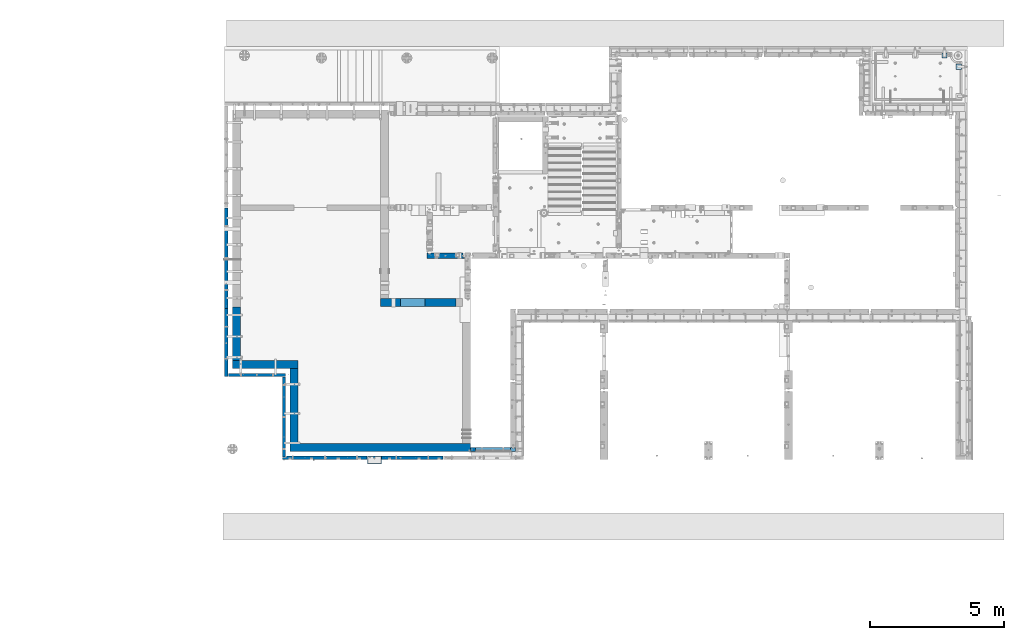
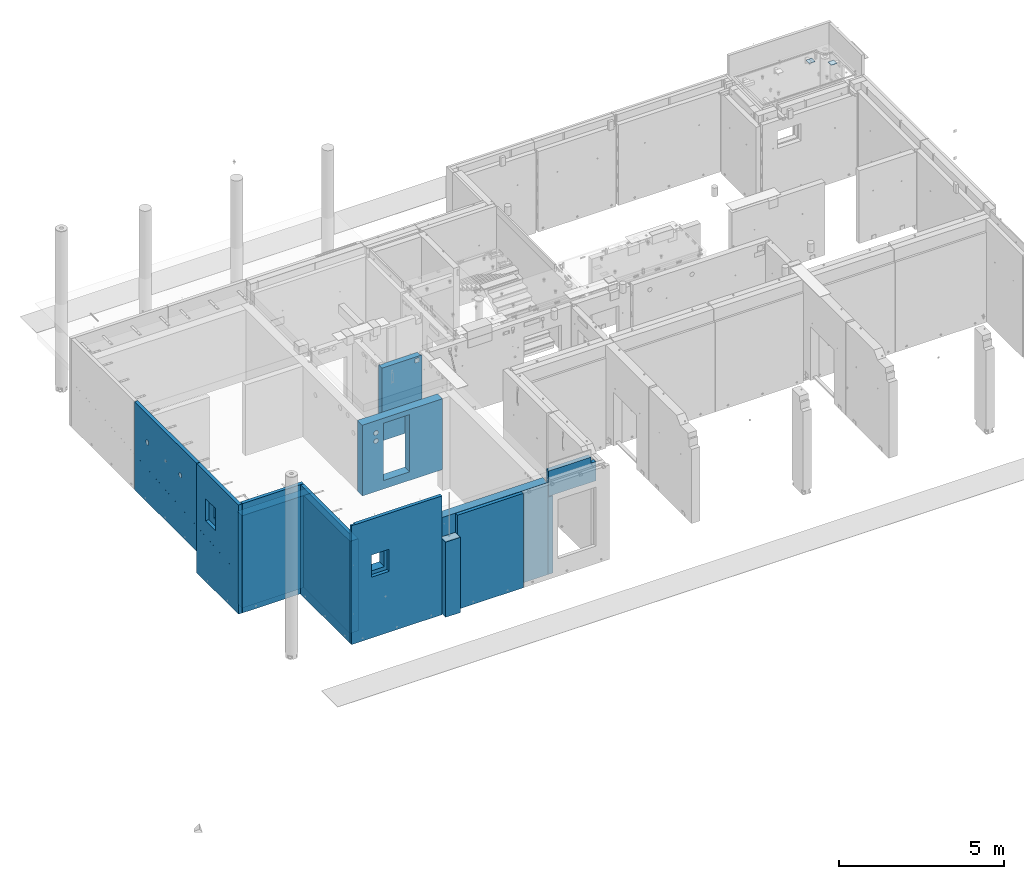
# One storey, part 170 of 264: 15 walls, 2 plates, 16 elements without a shape of their own.
"""IFC2X3 building model written with IfcOpenShell, lengths in millimetres."""

from ifc_helpers import new_model, si_unit, frame, origin_with_axes, place, context, subcontext, project, spatial, faceted_brep, material, type_object, element, aggregate, save


model = new_model("IFC2X3")

# Units and contexts
model_context = context("Model", 3, precision=1e-05, world=origin_with_axes())
body_context = subcontext(model_context, "Body", "Model", "MODEL_VIEW")
ifc_project = project(units=[si_unit("LENGTHUNIT", "METRE", prefix="MILLI"), si_unit("AREAUNIT", "SQUARE_METRE"), si_unit("VOLUMEUNIT", "CUBIC_METRE"), si_unit("MASSUNIT", "GRAM", prefix="KILO"), si_unit("TIMEUNIT", "SECOND"), si_unit("PLANEANGLEUNIT", "RADIAN"), si_unit("SOLIDANGLEUNIT", "STERADIAN"), si_unit("THERMODYNAMICTEMPERATUREUNIT", "DEGREE_CELSIUS"), si_unit("LUMINOUSINTENSITYUNIT", "LUMEN")], contexts=[model_context])

# Site, building, storey
site_placement = place(None, origin_with_axes())
site = spatial("IfcSite", under=ifc_project, at=site_placement, CompositionType="ELEMENT")
building_placement = place(site_placement, origin_with_axes())
building = spatial("IfcBuilding", under=site, at=building_placement, CompositionType="ELEMENT")
storey_placement = place(building_placement, origin_with_axes())
storey = spatial("IfcBuildingStorey", under=building, at=storey_placement, Name="K", CompositionType="ELEMENT", Elevation=0.0)

# Assemblies, plates
assembly_1_placement = place(storey_placement, origin_with_axes())
assembly_1 = element("IfcElementAssembly", 1, at=assembly_1_placement, inside=storey, AssemblyPlace="NOTDEFINED", PredefinedType="REINFORCEMENT_UNIT")
assembly_2_placement = place(assembly_1_placement, origin_with_axes())
assembly_2 = element("IfcElementAssembly", 2, at=assembly_2_placement, Name="Steel Assembly", AssemblyPlace="NOTDEFINED", PredefinedType="RIGID_FRAME")
ifc_material_1 = material(Name="STEEL/Steel_Undefined")
plate_type = type_object("IfcPlateType", PredefinedType="NOTDEFINED")
plate_1_placement = place(assembly_2_placement, frame((34934.9994523292, 22350.0101493348, 81451.0), z_axis=(-3.04539999856137e-05, -0.999999999536277, 0.0), x_axis=(0.999999999536277, -3.04539999891935e-05, 0.0)))
plate_1 = element("IfcPlate", 3, at=plate_1_placement, type_object=plate_type, material=ifc_material_1, Name="200x200", context=body_context, shape_type="Brep", body=[
    faceted_brep([(0.0, -6.0, -1.45519152283669e-11), (0.0, -6.0, 199.999999999996), (0.0, 6.0, 199.999999999996), (0.0, 6.0, -1.45519152283669e-11), (200.0, -6.0, 200.0), (200.0, 6.0, 200.0), (200.0, -6.0, -3.63797880709171e-12), (200.0, 6.0, -3.63797880709171e-12)], [[[0, 1, 2, 3]], [[1, 4, 5, 2]], [[4, 6, 7, 5]], [[6, 0, 3, 7]], [[5, 7, 3, 2]], [[6, 4, 1, 0]]]),
])
aggregate(assembly_2, [plate_1])
assembly_3_placement = place(assembly_1_placement, origin_with_axes())
assembly_3 = element("IfcElementAssembly", 4, at=assembly_3_placement, Name="Steel Assembly", AssemblyPlace="NOTDEFINED", PredefinedType="RIGID_FRAME")
aggregate(assembly_1, [assembly_2, assembly_3])
plate_2_placement = place(assembly_3_placement, frame((34399.9994523284, 22770.0101493342, 81451.0), z_axis=(-3.04539999856137e-05, -0.999999999536277, 0.0), x_axis=(0.999999999536277, -3.04539999891935e-05, 0.0)))
plate_2 = element("IfcPlate", 5, at=plate_2_placement, type_object=plate_type, material=ifc_material_1, Name="200x200", context=body_context, shape_type="Brep", body=[
    faceted_brep([(0.0, -6.0, -1.45519152283669e-11), (0.0, -6.0, 199.999999999996), (0.0, 6.0, 199.999999999996), (0.0, 6.0, -1.45519152283669e-11), (200.0, -6.0, 200.0), (200.0, 6.0, 200.0), (200.0, -6.0, -3.63797880709171e-12), (200.0, 6.0, -3.63797880709171e-12)], [[[0, 1, 2, 3]], [[1, 4, 5, 2]], [[4, 6, 7, 5]], [[6, 0, 3, 7]], [[5, 7, 3, 2]], [[6, 4, 1, 0]]]),
])
aggregate(assembly_3, [plate_2])

# Assembly, wall
assembly_4_placement = place(storey_placement, origin_with_axes())
assembly_4 = element("IfcElementAssembly", 6, at=assembly_4_placement, inside=storey, AssemblyPlace="NOTDEFINED", PredefinedType="REINFORCEMENT_UNIT")
ifc_material_2 = material(Name="CONCRETE/C40/50")
wall_type_1 = type_object("IfcWallType", PredefinedType="NOTDEFINED")
wall_1_placement = place(assembly_4_placement, frame((12910.0, 7530.00000961524, 79092.502949589), z_axis=(0.0, 0.0, 1.0), x_axis=(1.0, 0.0, 0.0)))
wall_1 = element("IfcWall", 7, at=wall_1_placement, type_object=wall_type_1, material=ifc_material_2, context=body_context, shape_type="Brep", body=[
    faceted_brep([(0.0, 150.0, -1392.5), (0.0, 150.0, 1392.5), (515.000007466682, 150.0, 1392.5), (515.000007466682, 150.0, -1392.5), (0.0, -150.0, 1392.5), (515.000007466682, -150.0, 1392.5), (0.0, -150.0, -1392.5), (515.000007466682, -150.0, -1392.5)], [[[0, 1, 2, 3]], [[1, 4, 5, 2]], [[4, 6, 7, 5]], [[6, 0, 3, 7]], [[5, 7, 3, 2]], [[6, 4, 1, 0]]]),
])

assembly_5_placement = place(storey_placement, origin_with_axes())
assembly_5 = element("IfcElementAssembly", 8, at=assembly_5_placement, inside=storey, AssemblyPlace="NOTDEFINED", PredefinedType="REINFORCEMENT_UNIT")
ifc_material_3 = material(Name="CONCRETE/Concrete_Undefined")
wall_type_2 = type_object("IfcWallType", PredefinedType="NOTDEFINED")
wall_2_placement = place(assembly_5_placement, frame((16850.0, 7850.00010372092, 79080.0), z_axis=(0.0, 0.0, 1.0), x_axis=(0.0, 1.0, 0.0)))
wall_2 = element("IfcWall", 9, at=wall_2_placement, type_object=wall_type_2, material=ifc_material_3, context=body_context, shape_type="Brep", body=[
    faceted_brep([(0.0, 90.0, -1430.0), (0.0, 90.0, 1430.0), (149.999961809157, 90.0, 1430.0), (149.999961809157, 90.0, -1430.0), (0.0, -90.0, 1430.0), (149.999961809157, -90.0, 1430.0), (0.0, -90.0, -1430.0), (149.999961809157, -90.0, -1430.0)], [[[0, 1, 2, 3]], [[1, 4, 5, 2]], [[4, 6, 7, 5]], [[6, 0, 3, 7]], [[5, 7, 3, 2]], [[6, 4, 1, 0]]]),
])

assembly_6_placement = place(storey_placement, origin_with_axes())
assembly_6 = element("IfcElementAssembly", 10, at=assembly_6_placement, inside=storey, AssemblyPlace="NOTDEFINED", PredefinedType="REINFORCEMENT_UNIT")
ifc_material_4 = material(Name="CONCRETE/C30/37")
wall_type_3 = type_object("IfcWallType", PredefinedType="NOTDEFINED")
wall_3_placement = place(assembly_6_placement, frame((18440.0000657818, 7925.00000000019, 81002.5), z_axis=(0.0, 0.0, 1.0), x_axis=(-1.0, 3.00000001838171e-08, 0.0)))
wall_3 = element("IfcWall", 11, at=wall_3_placement, type_object=wall_type_3, material=ifc_material_4, context=body_context, shape_type="Brep", body=[
    faceted_brep([(116.998555975799, -55.0010703084035, 237.5), (116.998555975799, -55.0010703084035, -467.500000000015), (129.998541787256, -75.0, -467.5), (129.998541787292, -75.0000042866541, 237.5), (42.9985568943812, -55.0010022399047, 237.5), (42.9985568943812, -55.0010022399047, -467.500000000015), (29.9985398258796, -75.0009920218718, 237.5), (29.9985398258832, -75.0, -467.5), (174.999743196975, -75.0000034214236, 467.5), (174.99987474698, 74.9999999999982, 467.5), (174.99987474698, 75.0, 237.5), (174.999743196975, -75.000005770552, 237.5), (1634.99903126282, -75.0000319658948, 467.5), (1634.99912738068, 32.0000269474131, 467.5), (1664.99906856749, 45.0000002495544, 467.5), (1664.99906856749, 74.9999999999991, 467.5), (1634.99903126282, -75.0, -467.5), (1634.99912738068, 32.0000269474131, -467.5), (1664.99906856749, 45.0000002495544, -467.5), (1664.99906856749, 74.9999999999991, -467.5), (0.0, 74.9999999999991, -467.5), (0.0, 74.9999999999991, 237.5), (-3.63797880709171e-12, -75.0, -467.5), (-3.63797880709171e-12, -75.0, 237.5)], [[[0, 1, 2, 3]], [[4, 5, 1, 0]], [[6, 7, 5, 4]], [[8, 9, 10, 11]], [[12, 13, 14, 15, 9, 8]], [[12, 16, 17, 13]], [[13, 17, 18, 14]], [[19, 15, 14, 18]], [[9, 15, 19, 20, 21, 10]], [[20, 22, 23, 21]], [[0, 3, 11, 10, 21, 23, 6, 4]], [[16, 12, 8, 11, 3, 2]], [[22, 20, 19, 18, 17, 16, 2, 1, 5, 7]], [[23, 22, 7, 6]]]),
])
aggregate(assembly_6, [wall_3])

# Wall
wall_type_4 = type_object("IfcWallType", PredefinedType="NOTDEFINED")
wall_4_placement = place(assembly_4_placement, frame((15735.0, 7620.0, 79445.0), z_axis=(0.0, 0.0, 1.0), x_axis=(-1.0, 3.00000001838171e-08, 0.0)))
wall_4 = element("IfcWall", 12, at=wall_4_placement, type_object=wall_type_4, material=ifc_material_2, context=body_context, shape_type="Brep", body=[
    faceted_brep([(0.0, 60.0, -1745.0), (0.0, 60.0, 1745.0), (2310.0, 60.0, 1745.0), (2310.0, 60.0, -1745.0), (0.0, -60.0, 1745.0), (2310.0, -60.0, 1745.0), (0.0, -60.0, -1745.0), (2310.0, -60.0, -1745.0)], [[[0, 1, 2, 3]], [[1, 4, 5, 2]], [[4, 6, 7, 5]], [[6, 0, 3, 7]], [[5, 7, 3, 2]], [[6, 4, 1, 0]]]),
])

aggregate(assembly_4, [wall_1, wall_4])

# Assembly, wall
assembly_7_placement = place(storey_placement, origin_with_axes())
assembly_7 = element("IfcElementAssembly", 13, at=assembly_7_placement, inside=storey, AssemblyPlace="NOTDEFINED", PredefinedType="REINFORCEMENT_UNIT")
wall_type_5 = type_object("IfcWallType", PredefinedType="NOTDEFINED")
wall_5_placement = place(assembly_7_placement, frame((12895.0, 7620.0, 79897.5), z_axis=(0.0, 0.0, 1.0), x_axis=(-1.0, 3.00000001838171e-08, 0.0)))
wall_5 = element("IfcWall", 14, at=wall_5_placement, type_object=wall_type_5, material=ifc_material_2, context=body_context, shape_type="Brep", body=[
    faceted_brep([(3025.0, -10.0, 2197.5), (3025.0, -10.0, 1292.5), (3175.0, -10.0, 1292.5), (3175.0, -10.0, 2197.5), (3025.0, -60.0, 2197.5), (3025.0, -60.0, 1292.5), (3175.0, -10.0, -2197.5), (3025.0, -10.0, -2197.5), (3025.0, -60.0, -2197.5), (0.0, -60.0, -2197.5), (0.0, 60.0, -2197.5), (3175.0, 60.0, -2197.5), (0.0, -60.0, 2197.5), (0.0, 60.0, 2197.5), (3175.0, 60.0, 2197.5), (2470.0695052743, 59.9996200203896, 52.5), (2470.0695052743, 59.9996200203896, 872.5), (1860.06912380457, 59.9996200203896, 872.5), (1860.06912380457, 59.9996200203896, 52.5), (1860.06912380457, -60.0, 52.5), (1860.06912380457, -60.0, 872.5), (2470.0695052743, -60.0, 52.5), (2470.0695052743, -60.0, 872.5)], [[[0, 1, 2, 3]], [[4, 5, 1, 0]], [[6, 2, 1, 7]], [[8, 7, 1, 5]], [[9, 10, 11, 6, 7, 8]], [[9, 12, 13, 10]], [[3, 14, 13, 12, 4, 0]], [[6, 11, 14, 3, 2]], [[10, 13, 14, 11], [15, 16, 17, 18]], [[19, 18, 17, 20]], [[21, 15, 18, 19]], [[22, 16, 15, 21]], [[20, 17, 16, 22]], [[12, 9, 8, 5, 4], [21, 19, 20, 22]]]),
])
aggregate(assembly_7, [wall_5])

# Wall
wall_type_6 = type_object("IfcWallType", PredefinedType="NOTDEFINED")
wall_6_placement = place(assembly_5_placement, frame((10010.0009314348, 7999.99701377227, 79355.0), z_axis=(0.0, 0.0, 1.0), x_axis=(1.0, 0.0, 0.0)))
wall_6 = element("IfcWall", 15, at=wall_6_placement, type_object=wall_type_6, material=ifc_material_3, context=body_context, shape_type="Brep", body=[
    faceted_brep([(6730.00003349592, -111.998474681339, 1705.0), (6730.00003349592, -111.998474681339, 1155.0), (6730.00003553767, -37.998474640417, 1155.0), (6730.00003553767, -37.998474640417, 1705.0), (6750.00003614728, -124.998473952346, 1705.0), (6750.00003427855, -124.998473952346, 1155.0), (6750.00003614728, -24.9984742298175, 1155.0), (6750.00003614728, -24.9984742298175, 1705.0), (0.0, -150.0, -1705.0), (0.0, -150.0, 1705.0), (0.0, 150.0, 1705.0), (0.0, 150.0, -1705.0), (6750.00003614728, 150.0, -1705.0), (6750.00003614728, -150.0, -1705.0), (6750.00003614728, -150.0, 1705.0), (414.929563290858, -150.0, 595.0), (414.929563290858, -150.0, 1415.0), (1024.92994476058, -150.0, 1415.0), (1024.92994476058, -150.0, 595.0), (1024.92994476058, 150.0, 595.0), (1024.92994476058, 150.0, 1415.0), (414.929563290858, 150.0, 595.0), (414.929563290858, 150.0, 1415.0), (6750.00003614728, 150.0, 1705.0)], [[[0, 1, 2, 3]], [[4, 5, 1, 0]], [[6, 2, 1, 5]], [[7, 3, 2, 6]], [[8, 9, 10, 11]], [[8, 11, 12, 13]], [[9, 8, 13, 14], [15, 16, 17, 18]], [[19, 18, 17, 20]], [[21, 15, 18, 19]], [[22, 16, 15, 21]], [[20, 17, 16, 22]], [[11, 10, 23, 12], [21, 19, 20, 22]], [[5, 4, 14, 13, 12, 23, 7, 6]], [[23, 10, 9, 14, 4, 0, 3, 7]]]),
])

aggregate(assembly_5, [wall_2, wall_6])

# Assembly, wall
assembly_8_placement = place(storey_placement, origin_with_axes())
assembly_8 = element("IfcElementAssembly", 16, at=assembly_8_placement, inside=storey, AssemblyPlace="NOTDEFINED", PredefinedType="REINFORCEMENT_UNIT")
wall_7_placement = place(assembly_8_placement, frame((10160.0039831927, 8150.00006553008, 79355.0), z_axis=(0.0, 0.0, 1.0), x_axis=(0.0, 1.0, 0.0)))
wall_7 = element("IfcWall", 17, at=wall_7_placement, type_object=wall_type_6, material=ifc_material_3, context=body_context, shape_type="Brep", body=[
    faceted_brep([(0.0, 150.0, -1705.0), (0.0, 150.0, 1705.0), (2800.00305175781, 150.0, 1705.0), (2800.00305175781, 150.0, -1705.0), (0.0, -150.0, 1705.0), (2800.00305175781, -150.0, 1705.0), (0.0, -150.0, -1705.0), (2800.00305175781, -150.0, -1705.0)], [[[0, 1, 2, 3]], [[1, 4, 5, 2]], [[4, 6, 7, 5]], [[6, 0, 3, 7]], [[5, 7, 3, 2]], [[6, 4, 1, 0]]]),
])
aggregate(assembly_8, [wall_7])

assembly_9_placement = place(storey_placement, origin_with_axes())
assembly_9 = element("IfcElementAssembly", 18, at=assembly_9_placement, inside=storey, AssemblyPlace="NOTDEFINED", PredefinedType="REINFORCEMENT_UNIT")
wall_8_placement = place(assembly_9_placement, frame((7850.00001965494, 11100.0031172879, 79355.0), z_axis=(0.0, 0.0, 1.0), x_axis=(1.0, 0.0, 0.0)))
wall_8 = element("IfcWall", 19, at=wall_8_placement, type_object=wall_type_6, material=ifc_material_3, context=body_context, shape_type="Brep", body=[
    faceted_brep([(0.0, 150.0, -1705.0), (0.0, 150.0, 1705.0), (2460.00396353772, 150.0, 1705.0), (2460.00396353772, 150.0, -1705.0), (0.0, -150.0, 1705.0), (2460.00396353772, -150.0, 1705.0), (0.0, -150.0, -1705.0), (2460.00396353772, -150.0, -1705.0)], [[[0, 1, 2, 3]], [[1, 4, 5, 2]], [[4, 6, 7, 5]], [[6, 0, 3, 7]], [[5, 7, 3, 2]], [[6, 4, 1, 0]]]),
])
aggregate(assembly_9, [wall_8])

assembly_10_placement = place(storey_placement, origin_with_axes())
assembly_10 = element("IfcElementAssembly", 20, at=assembly_10_placement, inside=storey, AssemblyPlace="NOTDEFINED", PredefinedType="REINFORCEMENT_UNIT")
wall_9_placement = place(assembly_10_placement, frame((8000.00032108328, 11249.9985396512, 79355.0), z_axis=(0.0, 0.0, 1.0), x_axis=(0.0, 1.0, 0.0)))
wall_9 = element("IfcWall", 21, at=wall_9_placement, type_object=wall_type_6, material=ifc_material_3, context=body_context, shape_type="Brep", body=[
    faceted_brep([(1410.00195476936, -150.0, 595.0), (1410.00195476936, 150.0, 595.0), (800.001573299629, 150.0, 595.0), (800.001573299629, -150.0, 595.0), (800.001573299629, 150.0, 1415.0), (800.001573299629, -150.0, 1415.0), (1410.00195476936, 150.0, 1415.0), (1410.00195476936, -150.0, 1415.0), (0.0, -150.0, 1705.0), (0.0, -150.0, -1705.0), (2005.00146034883, -150.0, -1705.0), (2005.00146034883, -150.0, 1705.0), (0.0, 150.0, 1705.0), (2005.00146034883, 150.0, 1705.0), (0.0, 150.0, -1705.0), (2005.00146034883, 150.0, -1705.0)], [[[0, 1, 2, 3]], [[3, 2, 4, 5]], [[5, 4, 6, 7]], [[7, 6, 1, 0]], [[8, 9, 10, 11], [3, 5, 7, 0]], [[12, 8, 11, 13]], [[9, 8, 12, 14]], [[9, 14, 15, 10]], [[11, 10, 15, 13]], [[14, 12, 13, 15], [2, 1, 6, 4]]]),
])
aggregate(assembly_10, [wall_9])

assembly_11_placement = place(storey_placement, origin_with_axes())
assembly_11 = element("IfcElementAssembly", 22, at=assembly_11_placement, inside=storey, AssemblyPlace="NOTDEFINED", PredefinedType="REINFORCEMENT_UNIT")
ifc_material_5 = material(Name="CONCRETE/C25/30")
wall_type_7 = type_object("IfcWallType", PredefinedType="NOTDEFINED")
wall_10_placement = place(assembly_11_placement, frame((15130.0, 15180.0, 80122.5), z_axis=(0.0, 0.0, 1.0), x_axis=(1.0, 0.0, 0.0)))
wall_10 = element("IfcWall", 23, at=wall_10_placement, type_object=wall_type_7, material=ifc_material_5, context=body_context, shape_type="Brep", body=[
    faceted_brep([(1149.99992221594, 100.0, 1287.50244328768), (1149.99992221594, -100.0, 1287.50244328768), (1149.99992221594, -100.0, 1137.50244328768), (1149.99992221594, 100.0, 1137.50244328768), (1299.99992221594, -100.0, 1137.50244328768), (1299.99992221594, 100.0, 1137.50244328768), (1299.99992221594, -100.0, 1287.50244328768), (1299.99992221594, 100.0, 1287.50244328768), (165.0, 100.0, 1347.5), (165.0, 100.0, -1347.5), (152.0, 80.0, -1347.5), (152.0, 80.0, 1347.5), (48.0, 80.0, -1347.5), (48.0, 80.0, 1347.5), (34.9999999999982, 100.0, -1347.5), (34.9999999999982, 100.0, 1347.5), (0.0, 100.0, -1347.5), (0.0, 100.0, 1347.5), (0.0, -100.0, -1347.5), (0.0, -100.0, 1347.5), (1350.0, 100.0, 1347.5), (1400.0, -100.0, 1347.5), (1400.0, -69.9999999999982, 1347.5), (1350.0, -57.0, 1347.5), (1350.0, 100.0, -1347.5), (1400.0, -100.0, -1347.5), (1350.0, -57.0, -1347.5), (1400.0, -69.9999999999982, -1347.5)], [[[0, 1, 2, 3]], [[3, 2, 4, 5]], [[5, 4, 6, 7]], [[7, 6, 1, 0]], [[8, 9, 10, 11]], [[11, 10, 12, 13]], [[13, 12, 14, 15]], [[16, 17, 15, 14]], [[18, 19, 17, 16]], [[20, 8, 11, 13, 15, 17, 19, 21, 22, 23]], [[9, 8, 20, 24], [3, 5, 7, 0]], [[25, 18, 16, 14, 12, 10, 9, 24, 26, 27]], [[20, 23, 26, 24]], [[22, 27, 26, 23]], [[21, 25, 27, 22]], [[19, 18, 25, 21], [2, 1, 6, 4]]]),
])
aggregate(assembly_11, [wall_10])

assembly_12_placement = place(storey_placement, origin_with_axes())
assembly_12 = element("IfcElementAssembly", 24, at=assembly_12_placement, inside=storey, AssemblyPlace="NOTDEFINED", PredefinedType="REINFORCEMENT_UNIT")
wall_type_8 = type_object("IfcWallType", PredefinedType="NOTDEFINED")
wall_11_placement = place(assembly_12_placement, frame((7620.0, 13210.0, 80115.0), z_axis=(0.0, 0.0, 1.0), x_axis=(0.0, 1.0, 0.0)))
wall_11 = element("IfcWall", 25, at=wall_11_placement, type_object=wall_type_8, material=ifc_material_2, context=body_context, shape_type="Brep", body=[
    faceted_brep([(3760.0, 60.0, -309.574801838578), (0.0, 60.0, -685.574801838578), (0.0, 59.0002685189247, -685.574801838578), (3760.0, 59.0002685189247, -309.574801838578), (3760.0, 59.0002685189247, -294.499988406882), (0.0, 59.0002685189247, -670.499988406882), (0.0, 60.0, -670.499988406897), (3760.0, 60.0, -294.499988406897), (1.81898940354586e-12, 60.0000000000036, 1625.0), (3.63797880709171e-12, -59.9999999999927, 1625.0), (3760.0, -60.0, 1625.0), (3760.0, 60.0, 1625.0), (3.63797880709171e-12, -59.9999999999927, -1625.0), (1.81898940354586e-12, 60.0000000000036, -1625.0), (3760.0, 60.0, -1625.0), (3760.0, -60.0, -1625.0), (3047.27322537961, -60.0, 615.705523608209), (3047.27322537961, 60.0, 615.705523608209), (3049.99915927648, 60.0, 595.0), (3049.99915927648, -60.0, 595.0), (3039.28119157924, -60.0, 635.0), (3039.28119157924, 60.0, 635.0), (3026.56770177141, -60.0, 651.568542494919), (3026.56770177141, 60.0, 651.568542494919), (3009.99915927648, -60.0, 664.282032302755), (3009.99915927648, 60.0, 664.282032302755), (2990.70468288469, -60.0, 672.274066103128), (2990.70468288469, 60.0, 672.274066103128), (2969.99915927648, -60.0, 675.0), (2969.99915927648, 60.0, 675.0), (2949.29363566828, -60.0, 672.274066103128), (2949.29363566828, 60.0, 672.274066103128), (2929.99915927648, -60.0, 664.282032302755), (2929.99915927648, 60.0, 664.282032302755), (2913.43061678156, -60.0, 651.568542494919), (2913.43061678156, 60.0, 651.568542494919), (2900.71712697373, -60.0, 635.0), (2900.71712697373, 60.0, 635.0), (2892.72509317336, -60.0, 615.705523608209), (2892.72509317336, 60.0, 615.705523608209), (2889.99915927648, -60.0, 595.0), (2889.99915927648, 60.0, 595.0), (2892.72509317336, -60.0, 574.294476391791), (2892.72509317336, 60.0, 574.294476391791), (2900.71712697373, -60.0, 555.0), (2900.71712697373, 60.0, 555.0), (2913.43061678156, -60.0, 538.431457505081), (2913.43061678156, 60.0, 538.431457505081), (2929.99915927648, -60.0, 525.717967697245), (2929.99915927648, 60.0, 525.717967697245), (2949.29363566828, -60.0, 517.725933896872), (2949.29363566828, 60.0, 517.725933896872), (2969.99915927648, -60.0, 515.0), (2969.99915927648, 60.0, 515.0), (2990.70468288469, -60.0, 517.725933896872), (2990.70468288469, 60.0, 517.725933896872), (3009.99915927648, -60.0, 525.717967697245), (3009.99915927648, 60.0, 525.717967697245), (3026.56770177141, -60.0, 538.431457505081), (3026.56770177141, 60.0, 538.431457505081), (3039.28119157924, -60.0, 555.0), (3039.28119157924, 60.0, 555.0), (3047.27322537961, -60.0, 574.294476391791), (3047.27322537961, 60.0, 574.294476391791), (1047.27417905393, -60.0, 615.705523608209), (1047.27417905393, 60.0, 615.705523608209), (1050.0001129508, 60.0, 595.0), (1050.0001129508, -60.0, 595.0), (1039.28214525356, -60.0, 635.0), (1039.28214525356, 60.0, 635.0), (1026.56865544573, -60.0, 651.568542494919), (1026.56865544573, 60.0, 651.568542494919), (1010.0001129508, -60.0, 664.282032302755), (1010.0001129508, 60.0, 664.282032302755), (990.705636559003, -60.0, 672.274066103128), (990.705636559003, 60.0, 672.274066103128), (970.000112950802, -60.0, 675.0), (970.000112950802, 60.0, 675.0), (949.2945893426, -60.0, 672.274066103128), (949.2945893426, 60.0, 672.274066103128), (930.000112950802, -60.0, 664.282032302755), (930.000112950802, 60.0, 664.282032302755), (913.431570455878, -60.0, 651.568542494919), (913.431570455878, 60.0, 651.568542494919), (900.718080648046, -60.0, 635.0), (900.718080648046, 60.0, 635.0), (892.726046847676, -60.0, 615.705523608209), (892.726046847676, 60.0, 615.705523608209), (890.000112950802, -60.0, 595.0), (890.000112950802, 60.0, 595.0), (892.726046847676, -60.0, 574.294476391791), (892.726046847676, 60.0, 574.294476391791), (900.718080648046, -60.0, 555.0), (900.718080648046, 60.0, 555.0), (913.431570455878, -60.0, 538.431457505081), (913.431570455878, 60.0, 538.431457505081), (930.000112950802, -60.0, 525.717967697245), (930.000112950802, 60.0, 525.717967697245), (949.2945893426, -60.0, 517.725933896872), (949.2945893426, 60.0, 517.725933896872), (970.000112950802, -60.0, 515.0), (970.000112950802, 60.0, 515.0), (990.705636559003, -60.0, 517.725933896872), (990.705636559003, 60.0, 517.725933896872), (1010.0001129508, -60.0, 525.717967697245), (1010.0001129508, 60.0, 525.717967697245), (1026.56865544573, -60.0, 538.431457505081), (1026.56865544573, 60.0, 538.431457505081), (1039.28214525356, -60.0, 555.0), (1039.28214525356, 60.0, 555.0), (1047.27417905393, -60.0, 574.294476391791), (1047.27417905393, 60.0, 574.294476391791), (1830.0001129508, -60.0, 585.0), (1822.92904513894, -60.0, 587.928932188137), (1820.0001129508, -60.0, 595.0), (1822.92904513894, -60.0, 602.071067811863), (1830.0001129508, -60.0, 605.0), (1837.07118076267, -60.0, 602.071067811863), (1840.0001129508, -60.0, 595.0), (1837.07118076267, -60.0, 587.928932188137), (1830.0001129508, 60.0, 605.0), (1837.07118076267, 60.0, 602.071067811863), (1822.92904513894, 60.0, 602.071067811863), (1820.0001129508, 60.0, 595.0), (1822.92904513894, 60.0, 587.928932188137), (1830.0001129508, 60.0, 585.0), (1837.07118076267, 60.0, 587.928932188137), (1840.0001129508, 60.0, 595.0)], [[[0, 1, 2, 3]], [[4, 5, 6, 7]], [[3, 2, 5, 4]], [[8, 9, 10, 11]], [[12, 13, 14, 15]], [[16, 17, 18, 19]], [[20, 21, 17, 16]], [[22, 23, 21, 20]], [[24, 25, 23, 22]], [[26, 27, 25, 24]], [[28, 29, 27, 26]], [[30, 31, 29, 28]], [[32, 33, 31, 30]], [[34, 35, 33, 32]], [[36, 37, 35, 34]], [[38, 39, 37, 36]], [[40, 41, 39, 38]], [[42, 43, 41, 40]], [[44, 45, 43, 42]], [[46, 47, 45, 44]], [[48, 49, 47, 46]], [[50, 51, 49, 48]], [[52, 53, 51, 50]], [[54, 55, 53, 52]], [[56, 57, 55, 54]], [[58, 59, 57, 56]], [[60, 61, 59, 58]], [[62, 63, 61, 60]], [[19, 18, 63, 62]], [[64, 65, 66, 67]], [[68, 69, 65, 64]], [[70, 71, 69, 68]], [[72, 73, 71, 70]], [[74, 75, 73, 72]], [[76, 77, 75, 74]], [[78, 79, 77, 76]], [[80, 81, 79, 78]], [[82, 83, 81, 80]], [[84, 85, 83, 82]], [[86, 87, 85, 84]], [[88, 89, 87, 86]], [[90, 91, 89, 88]], [[92, 93, 91, 90]], [[94, 95, 93, 92]], [[96, 97, 95, 94]], [[98, 99, 97, 96]], [[100, 101, 99, 98]], [[102, 103, 101, 100]], [[104, 105, 103, 102]], [[106, 107, 105, 104]], [[108, 109, 107, 106]], [[110, 111, 109, 108]], [[67, 66, 111, 110]], [[9, 12, 15, 10], [112, 113, 114, 115, 116, 117, 118, 119], [108, 106, 104, 102, 100, 98, 96, 94, 92, 90, 88, 86, 84, 82, 80, 78, 76, 74, 72, 70, 68, 64, 67, 110], [60, 58, 56, 54, 52, 50, 48, 46, 44, 42, 40, 38, 36, 34, 32, 30, 28, 26, 24, 22, 20, 16, 19, 62]], [[116, 120, 121, 117]], [[115, 122, 120, 116]], [[114, 123, 122, 115]], [[113, 124, 123, 114]], [[112, 125, 124, 113]], [[119, 126, 125, 112]], [[118, 127, 126, 119]], [[117, 121, 127, 118]], [[8, 11, 7, 6], [120, 122, 123, 124, 125, 126, 127, 121], [69, 71, 73, 75, 77, 79, 81, 83, 85, 87, 89, 91, 93, 95, 97, 99, 101, 103, 105, 107, 109, 111, 66, 65], [21, 23, 25, 27, 29, 31, 33, 35, 37, 39, 41, 43, 45, 47, 49, 51, 53, 55, 57, 59, 61, 63, 18, 17]], [[1, 13, 12, 9, 8, 6, 5, 2]], [[14, 13, 1, 0]], [[11, 10, 15, 14, 0, 3, 4, 7]]]),
])
aggregate(assembly_12, [wall_11])

assembly_13_placement = place(storey_placement, origin_with_axes())
assembly_13 = element("IfcElementAssembly", 26, at=assembly_13_placement, inside=storey, AssemblyPlace="NOTDEFINED", PredefinedType="REINFORCEMENT_UNIT")
wall_type_9 = type_object("IfcWallType", PredefinedType="NOTDEFINED")
wall_12_placement = place(assembly_13_placement, frame((9780.0, 7645.0, 79720.0), z_axis=(0.0, 0.0, 1.0), x_axis=(0.0, 1.0, 0.0)))
wall_12 = element("IfcWall", 27, at=wall_12_placement, type_object=wall_type_9, material=ifc_material_2, context=body_context, shape_type="Brep", body=[
    faceted_brep([(0.0, 60.0, -2020.0), (0.0, 60.0, 2020.0), (3000.0, 60.0, 2020.0), (3000.0, 60.0, -2020.0), (0.0, -60.0, 2020.0), (3000.0, -60.0, 2020.0), (0.0, -60.0, -2020.0), (3000.0, -60.0, -2020.0)], [[[0, 1, 2, 3]], [[1, 4, 5, 2]], [[4, 6, 7, 5]], [[6, 0, 3, 7]], [[5, 7, 3, 2]], [[6, 4, 1, 0]]]),
])
aggregate(assembly_13, [wall_12])

assembly_14_placement = place(storey_placement, origin_with_axes())
assembly_14 = element("IfcElementAssembly", 28, at=assembly_14_placement, inside=storey, AssemblyPlace="NOTDEFINED", PredefinedType="REINFORCEMENT_UNIT")
wall_13_placement = place(assembly_14_placement, frame((9840.0, 10720.0, 79720.0), z_axis=(0.0, 0.0, 1.0), x_axis=(-1.0, 3.00000001838171e-08, 0.0)))
wall_13 = element("IfcWall", 29, at=wall_13_placement, type_object=wall_type_9, material=ifc_material_2, context=body_context, shape_type="Brep", body=[
    faceted_brep([(0.0, 60.0, -2020.0), (0.0, 60.0, 2020.0), (2145.0, 60.0, 2020.0), (2145.0, 60.0, -2020.0), (0.0, -60.0, 2020.0), (2145.0, -60.0, 2020.0), (0.0, -60.0, -2020.0), (2145.0, -60.0, -2020.0)], [[[0, 1, 2, 3]], [[1, 4, 5, 2]], [[4, 6, 7, 5]], [[6, 0, 3, 7]], [[5, 7, 3, 2]], [[6, 4, 1, 0]]]),
])
aggregate(assembly_14, [wall_13])

assembly_15_placement = place(storey_placement, origin_with_axes())
assembly_15 = element("IfcElementAssembly", 30, at=assembly_15_placement, inside=storey, AssemblyPlace="NOTDEFINED", PredefinedType="REINFORCEMENT_UNIT")
wall_14_placement = place(assembly_15_placement, frame((7620.0, 10660.0, 79720.0), z_axis=(0.0, 0.0, 1.0), x_axis=(0.0, 1.0, 0.0)))
wall_14 = element("IfcWall", 31, at=wall_14_placement, type_object=wall_type_9, material=ifc_material_2, context=body_context, shape_type="Brep", body=[
    faceted_brep([(2535.0, 60.0, -292.074801838578), (0.0, 60.0, -545.574801838578), (0.0, 59.0002685189247, -545.574801838578), (2535.0, 59.0002685189247, -292.074801838578), (2535.0, 59.0002685189247, -276.999988406882), (0.0, 59.0002685189247, -530.499988406882), (0.0, 60.0, -530.499988406897), (2535.0, 60.0, -276.999988406897), (0.0, 60.0, 2020.0), (0.0, -60.0, 2020.0), (2535.0, -60.0, 2020.0), (2535.0, 60.0, 2020.0), (0.0, -60.0, -2020.0), (0.0, 60.0, -2020.0), (2535.0, 60.0, -2020.0), (2535.0, -60.0, -2020.0), (1390.0001129508, -60.0, 230.0), (1390.0001129508, -60.0, 1050.0), (2000.00049442053, -60.0, 1050.0), (2000.00049442053, -60.0, 230.0), (1390.0001129508, 60.0, 230.0), (1390.0001129508, 60.0, 1050.0), (2000.00049442053, 60.0, 230.0), (2000.00049442053, 60.0, 1050.0)], [[[0, 1, 2, 3]], [[4, 5, 6, 7]], [[3, 2, 5, 4]], [[8, 9, 10, 11]], [[12, 13, 14, 15]], [[9, 12, 15, 10], [16, 17, 18, 19]], [[16, 20, 21, 17]], [[19, 22, 20, 16]], [[18, 23, 22, 19]], [[17, 21, 23, 18]], [[8, 11, 7, 6], [20, 22, 23, 21]], [[1, 13, 12, 9, 8, 6, 5, 2]], [[14, 13, 1, 0]], [[11, 10, 15, 14, 0, 3, 4, 7]]]),
])
aggregate(assembly_15, [wall_14])

assembly_16_placement = place(storey_placement, origin_with_axes())
assembly_16 = element("IfcElementAssembly", 32, at=assembly_16_placement, inside=storey, AssemblyPlace="NOTDEFINED", PredefinedType="REINFORCEMENT_UNIT")
wall_type_10 = type_object("IfcWallType", PredefinedType="NOTDEFINED")
wall_15_placement = place(assembly_16_placement, frame((13400.0003210833, 13425.0000655301, 79750.0), z_axis=(0.0, 0.0, 1.0), x_axis=(1.0, 0.0, 0.0)))
wall_15 = element("IfcWall", 33, at=wall_15_placement, type_object=wall_type_10, material=ifc_material_3, context=body_context, shape_type="Brep", body=[
    faceted_brep([(557.542603393007, 150.0, 880.705523608209), (557.542603393007, -150.0, 880.705523608209), (549.550569592637, -150.0, 900.0), (549.550569592637, 150.0, 900.0), (536.837079784806, -150.0, 916.568542494919), (536.837079784806, 150.0, 916.568542494919), (520.268537289881, -150.0, 929.282032302755), (520.268537289881, 150.0, 929.282032302755), (500.974060898083, -150.0, 937.274066103128), (500.974060898083, 150.0, 937.274066103128), (480.268537289881, -150.0, 940.0), (480.268537289881, 150.0, 940.0), (459.56301368168, -150.0, 937.274066103128), (459.56301368168, 150.0, 937.274066103128), (440.268537289881, -150.0, 929.282032302755), (440.268537289881, 150.0, 929.282032302755), (423.699994794957, -150.0, 916.568542494919), (423.699994794957, 150.0, 916.568542494919), (410.986504987126, -150.0, 900.0), (410.986504987126, 150.0, 900.0), (402.994471186756, -150.0, 880.705523608209), (402.994471186756, 150.0, 880.705523608209), (400.268537289881, -150.0, 860.0), (400.268537289881, 150.0, 860.0), (402.994471186756, -150.0, 839.294476391791), (402.994471186756, 150.0, 839.294476391791), (410.986504987126, -150.0, 820.0), (410.986504987126, 150.0, 820.0), (423.699994794957, -150.0, 803.431457505081), (423.699994794957, 150.0, 803.431457505081), (440.268537289881, -150.0, 790.717967697245), (440.268537289881, 150.0, 790.717967697245), (459.56301368168, -150.0, 782.725933896872), (459.56301368168, 150.0, 782.725933896872), (480.268537289881, -150.0, 780.0), (480.268537289881, 150.0, 780.0), (500.974060898083, -150.0, 782.725933896872), (500.974060898083, 150.0, 782.725933896872), (520.268537289881, -150.0, 790.717967697245), (520.268537289881, 150.0, 790.717967697245), (536.837079784806, -150.0, 803.431457505081), (536.837079784806, 150.0, 803.431457505081), (549.550569592637, -150.0, 820.0), (549.550569592637, 150.0, 820.0), (557.542603393007, -150.0, 839.294476391791), (557.542603393007, 150.0, 839.294476391791), (560.268537289881, -150.0, 860.0), (560.268537289881, 150.0, 860.0), (0.0, 150.0, 1310.0), (0.0, -150.0, 1310.0), (2810.00061035156, -150.0, 1310.0), (2810.00061035156, 150.0, 1310.0), (0.0, -150.0, -1310.0), (0.0, 150.0, -1310.0), (2810.00061035156, 150.0, -1310.0), (2810.00061035156, -150.0, -1310.0), (1659.99877929688, 150.0, -995.0), (1659.99877929688, -150.0, -995.0), (1659.99877929688, -150.0, 1125.0), (1659.99877929688, 150.0, 1125.0), (745.0, 150.0, -995.0), (745.0, -150.0, -995.0), (745.0, 150.0, 1125.0), (745.0, -150.0, 1125.0), (549.550569592637, 150.0, 600.0), (536.837079784806, 150.0, 616.568542494919), (520.268537289881, 150.0, 629.282032302755), (500.974060898083, 150.0, 637.274066103128), (480.268537289881, 150.0, 640.0), (459.56301368168, 150.0, 637.274066103128), (440.268537289881, 150.0, 629.282032302755), (423.699994794957, 150.0, 616.568542494919), (410.986504987126, 150.0, 600.0), (402.994471186756, 150.0, 580.705523608209), (400.268537289881, 150.0, 560.0), (402.994471186756, 150.0, 539.294476391791), (410.986504987126, 150.0, 520.0), (423.699994794957, 150.0, 503.431457505081), (440.268537289881, 150.0, 490.717967697245), (459.56301368168, 150.0, 482.725933896872), (480.268537289881, 150.0, 480.0), (500.974060898083, 150.0, 482.725933896872), (520.268537289881, 150.0, 490.717967697245), (536.837079784806, 150.0, 503.431457505081), (549.550569592637, 150.0, 520.0), (557.542603393007, 150.0, 539.294476391791), (560.268537289881, 150.0, 560.0), (557.542603393007, 150.0, 580.705523608209), (549.550569592637, -150.0, 520.0), (557.542603393007, -150.0, 539.294476391791), (536.837079784806, -150.0, 503.431457505081), (520.268537289881, -150.0, 490.717967697245), (500.974060898083, -150.0, 482.725933896872), (480.268537289881, -150.0, 480.0), (459.56301368168, -150.0, 482.725933896872), (440.268537289881, -150.0, 490.717967697245), (423.699994794957, -150.0, 503.431457505081), (410.986504987126, -150.0, 520.0), (402.994471186756, -150.0, 539.294476391791), (400.268537289881, -150.0, 560.0), (402.994471186756, -150.0, 580.705523608209), (410.986504987126, -150.0, 600.0), (423.699994794957, -150.0, 616.568542494919), (440.268537289881, -150.0, 629.282032302755), (459.56301368168, -150.0, 637.274066103128), (480.268537289881, -150.0, 640.0), (500.974060898083, -150.0, 637.274066103128), (520.268537289881, -150.0, 629.282032302755), (536.837079784806, -150.0, 616.568542494919), (549.550569592637, -150.0, 600.0), (557.542603393007, -150.0, 580.705523608209), (560.268537289881, -150.0, 560.0)], [[[0, 1, 2, 3]], [[3, 2, 4, 5]], [[5, 4, 6, 7]], [[7, 6, 8, 9]], [[9, 8, 10, 11]], [[11, 10, 12, 13]], [[13, 12, 14, 15]], [[15, 14, 16, 17]], [[17, 16, 18, 19]], [[19, 18, 20, 21]], [[21, 20, 22, 23]], [[23, 22, 24, 25]], [[25, 24, 26, 27]], [[27, 26, 28, 29]], [[29, 28, 30, 31]], [[31, 30, 32, 33]], [[33, 32, 34, 35]], [[35, 34, 36, 37]], [[37, 36, 38, 39]], [[39, 38, 40, 41]], [[41, 40, 42, 43]], [[43, 42, 44, 45]], [[45, 44, 46, 47]], [[47, 46, 1, 0]], [[48, 49, 50, 51]], [[52, 49, 48, 53]], [[52, 53, 54, 55]], [[50, 55, 54, 51]], [[56, 57, 58, 59]], [[60, 61, 57, 56]], [[62, 63, 61, 60]], [[59, 58, 63, 62]], [[53, 48, 51, 54], [3, 5, 7, 9, 11, 13, 15, 17, 19, 21, 23, 25, 27, 29, 31, 33, 35, 37, 39, 41, 43, 45, 47, 0], [64, 65, 66, 67, 68, 69, 70, 71, 72, 73, 74, 75, 76, 77, 78, 79, 80, 81, 82, 83, 84, 85, 86, 87], [60, 56, 59, 62]], [[84, 88, 89, 85]], [[83, 90, 88, 84]], [[82, 91, 90, 83]], [[81, 92, 91, 82]], [[80, 93, 92, 81]], [[79, 94, 93, 80]], [[78, 95, 94, 79]], [[77, 96, 95, 78]], [[76, 97, 96, 77]], [[75, 98, 97, 76]], [[74, 99, 98, 75]], [[73, 100, 99, 74]], [[72, 101, 100, 73]], [[71, 102, 101, 72]], [[70, 103, 102, 71]], [[69, 104, 103, 70]], [[68, 105, 104, 69]], [[67, 106, 105, 68]], [[66, 107, 106, 67]], [[65, 108, 107, 66]], [[64, 109, 108, 65]], [[87, 110, 109, 64]], [[86, 111, 110, 87]], [[85, 89, 111, 86]], [[49, 52, 55, 50], [42, 40, 38, 36, 34, 32, 30, 28, 26, 24, 22, 20, 18, 16, 14, 12, 10, 8, 6, 4, 2, 1, 46, 44], [88, 90, 91, 92, 93, 94, 95, 96, 97, 98, 99, 100, 101, 102, 103, 104, 105, 106, 107, 108, 109, 110, 111, 89], [61, 63, 58, 57]]]),
])
aggregate(assembly_16, [wall_15])

save(model, "model.ifc")
